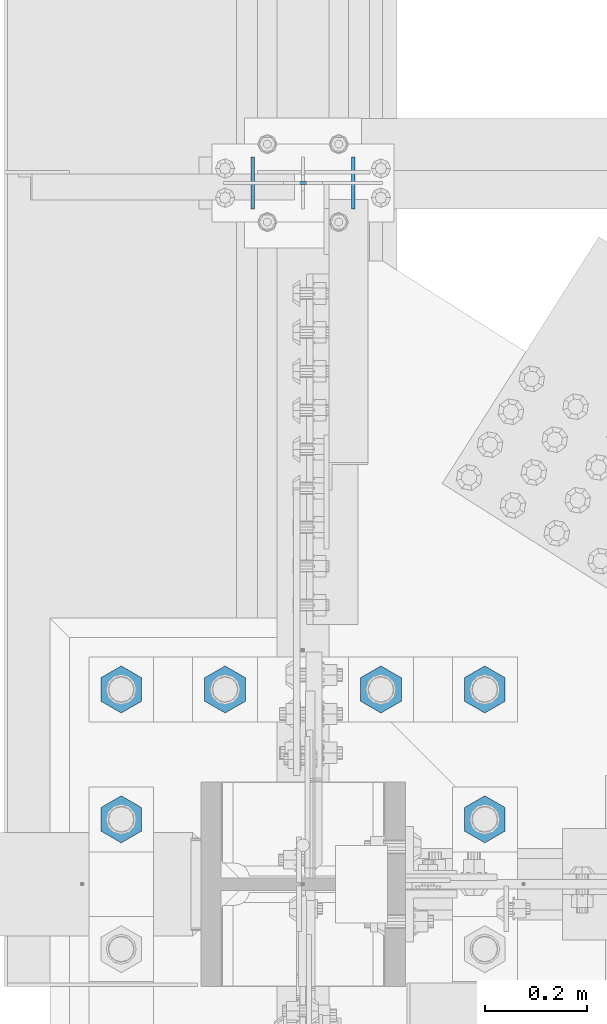
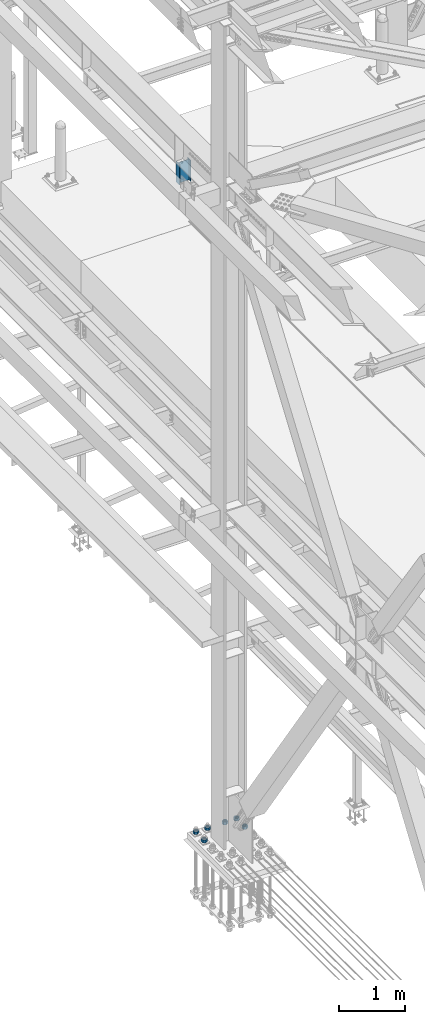
# One storey, part 1556 of 3843: 7 columns, 2 elements without a shape of their own.
"""IFC2X3 building model written with IfcOpenShell, lengths in millimetres."""

from ifc_helpers import new_model, si_unit, frame, origin_with_axes, place, context, subcontext, project, spatial, faceted_brep, material, type_object, element, aggregate, save


model = new_model("IFC2X3")

# Units and contexts
model_context = context("Model", 3, precision=1e-05, world=origin_with_axes())
body_context = subcontext(model_context, "Body", "Model", "MODEL_VIEW")
ifc_project = project(units=[si_unit("LENGTHUNIT", "METRE", prefix="MILLI"), si_unit("AREAUNIT", "SQUARE_METRE"), si_unit("VOLUMEUNIT", "CUBIC_METRE"), si_unit("MASSUNIT", "GRAM", prefix="KILO"), si_unit("TIMEUNIT", "SECOND"), si_unit("PLANEANGLEUNIT", "RADIAN"), si_unit("SOLIDANGLEUNIT", "STERADIAN"), si_unit("THERMODYNAMICTEMPERATUREUNIT", "DEGREE_CELSIUS"), si_unit("LUMINOUSINTENSITYUNIT", "LUMEN")], contexts=[model_context])

# Site, building, storey
site_placement = place(None, origin_with_axes())
site = spatial("IfcSite", under=ifc_project, at=site_placement, CompositionType="ELEMENT")
building_placement = place(site_placement, origin_with_axes())
building = spatial("IfcBuilding", under=site, at=building_placement, Name="Undefined", CompositionType="ELEMENT")
storey_placement = place(building_placement, origin_with_axes())
storey = spatial("IfcBuildingStorey", under=building, at=storey_placement, Name="Undefined", CompositionType="ELEMENT", Elevation=0.0)

# Assembly, column
assembly_1_placement = place(storey_placement, origin_with_axes())
assembly_1 = element("IfcElementAssembly", 1, at=assembly_1_placement, inside=storey, Name="POST", AssemblyPlace="NOTDEFINED", PredefinedType="RIGID_FRAME")
ifc_material_1 = material(Name="STEEL/A992")
column_type_1 = type_object("IfcColumnType", Name="W8X13", PredefinedType="NOTDEFINED")
column_1_placement = place(assembly_1_placement, frame((36576.0000030518, 77000.1, 41503.6), z_axis=(-1.0, 0.0, 0.0), x_axis=(0.0, 0.0, 1.0)))
column_1 = element("IfcColumn", 2, at=column_1_placement, type_object=column_type_1, material=ifc_material_1, Name="POST", ObjectType="W8X13", context=body_context, shape_type="Brep", body=[
    faceted_brep([(19.0499994920028, 50.7999999999993, -101.600000000035), (19.0499995237551, 50.7999999999993, -95.2500000000364), (403.224999428487, 50.7999999999993, -95.2499999989232), (403.22499939039, 50.7999999999993, -101.599999998929), (19.0499995237551, 3.17499999999927, -95.2500000000364), (403.224999428487, 3.17499999999927, -95.2499999989232), (19.0500004762507, 3.17499999999927, 95.2499999999636), (403.225000571489, 3.17499999999927, 95.2500000010768), (19.0500004762507, 50.7999999999993, 95.2499999999636), (403.225000571489, 50.7999999999993, 95.2500000010768), (19.050000508003, 50.7999999999993, 101.599999999969), (403.225000609593, 50.7999999999993, 101.600000001075), (19.050000508003, -50.7999999999993, 101.599999999969), (403.225000609593, -50.7999999999993, 101.600000001075), (19.0500004762507, -50.7999999999993, 95.2499999999636), (403.225000571489, -50.7999999999993, 95.2500000010768), (19.0500004762507, -3.17499999999927, 95.2499999999636), (403.225000571489, -3.17499999999927, 95.2500000010768), (19.0499995237551, -3.17499999999927, -95.2500000000364), (403.224999428487, -3.17499999999927, -95.2499999989232), (19.0499995237551, -50.7999999999993, -95.2500000000364), (403.224999428487, -50.7999999999993, -95.2499999989232), (19.0499994920028, -50.7999999999993, -101.600000000035), (403.22499939039, -50.7999999999993, -101.599999998929)], [[[0, 1, 2, 3]], [[1, 4, 5, 2]], [[4, 6, 7, 5]], [[6, 8, 9, 7]], [[8, 10, 11, 9]], [[10, 12, 13, 11]], [[12, 14, 15, 13]], [[14, 16, 17, 15]], [[16, 18, 19, 17]], [[18, 20, 21, 19]], [[20, 22, 23, 21]], [[22, 0, 3, 23]], [[5, 7, 9, 11, 13, 15, 17, 19, 21, 23, 3, 2]], [[22, 20, 18, 16, 14, 12, 10, 8, 6, 4, 1, 0]]]),
])
aggregate(assembly_1, [column_1])

# Assembly, columns
assembly_2_placement = place(storey_placement, origin_with_axes())
assembly_2 = element("IfcElementAssembly", 3, at=assembly_2_placement, inside=storey, Name="TEMPLATE", AssemblyPlace="NOTDEFINED", PredefinedType="RIGID_FRAME")
ifc_material_2 = material(Name="STEEL/A572-50")
column_type_2 = type_object("IfcColumnType", Name="2_HEAVY_HEX_NUT", PredefinedType="NOTDEFINED")
column_2_placement = place(assembly_2_placement, frame((36931.6, 75755.5, 30232.35), z_axis=(-1.0, 0.0, 0.0), x_axis=(0.0, 0.0, -1.0)))
column_2 = element("IfcColumn", 4, at=column_2_placement, type_object=column_type_2, material=ifc_material_2, Name="NUT", ObjectType="2_HEAVY_HEX_NUT", context=body_context, shape_type="Brep", body=[
    faceted_brep([(0.0, -46.0369987487793, 0.0), (0.0, -23.0184993743896, -39.869213104248), (50.7999999999993, -23.0184993743896, -39.869213104248), (50.7999999999993, -46.0369987487793, 0.0), (0.0, 23.0184993743896, -39.869213104248), (50.7999999999993, 23.0184993743896, -39.869213104248), (0.0, 46.0369987487793, 0.0), (50.7999999999993, 46.0369987487793, 0.0), (0.0, 23.0184993743896, 39.869213104248), (50.7999999999993, 23.0184993743896, 39.869213104248), (0.0, -23.0184993743896, 39.869213104248), (50.7999999999993, -23.0184993743896, 39.869213104248), (0.0, 0.0, 26.1940002441406), (0.0, 11.3650617044477, 23.5999013092805), (50.7999999999993, 11.3650617044477, 23.5999013092805), (50.7999999999993, 0.0, 26.1940002441406), (0.0, 20.4791109456419, 16.3316083006721), (50.7999999999993, 20.4791109456419, 16.3316083006721), (0.0, 25.5370200498292, 5.82867859874386), (50.7999999999993, 25.5370200498292, 5.82867859874386), (0.0, 25.5370200498292, -5.82867859874386), (50.7999999999993, 25.5370200498292, -5.82867859874386), (0.0, 20.4791109456419, -16.3316083006721), (50.7999999999993, 20.4791109456419, -16.3316083006721), (0.0, 11.3650617044477, -23.5999013092805), (50.7999999999993, 11.3650617044477, -23.5999013092805), (0.0, 0.0, -26.1940002441406), (50.7999999999993, 0.0, -26.1940002441406), (0.0, -11.3650617044477, -23.5999013092805), (50.7999999999993, -11.3650617044477, -23.5999013092805), (0.0, -20.4791109456419, -16.3316083006721), (50.7999999999993, -20.4791109456419, -16.3316083006721), (0.0, -25.5370200498292, -5.82867859874386), (50.7999999999993, -25.5370200498292, -5.82867859874386), (0.0, -25.5370200498292, 5.82867859874386), (50.7999999999993, -25.5370200498292, 5.82867859874386), (0.0, -20.4791109456419, 16.3316083006721), (50.7999999999993, -20.4791109456419, 16.3316083006721), (0.0, -11.3650617044477, 23.5999013092805), (50.7999999999993, -11.3650617044477, 23.5999013092805)], [[[0, 1, 2, 3]], [[1, 4, 5, 2]], [[4, 6, 7, 5]], [[6, 8, 9, 7]], [[8, 10, 11, 9]], [[10, 0, 3, 11]], [[12, 13, 14, 15]], [[13, 16, 17, 14]], [[16, 18, 19, 17]], [[18, 20, 21, 19]], [[20, 22, 23, 21]], [[22, 24, 25, 23]], [[24, 26, 27, 25]], [[26, 28, 29, 27]], [[28, 30, 31, 29]], [[30, 32, 33, 31]], [[32, 34, 35, 33]], [[34, 36, 37, 35]], [[36, 38, 39, 37]], [[38, 12, 15, 39]], [[5, 7, 9, 11, 3, 2], [17, 19, 21, 23, 25, 27, 29, 31, 33, 35, 37, 39, 15, 14]], [[10, 8, 6, 4, 1, 0], [38, 36, 34, 32, 30, 28, 26, 24, 22, 20, 18, 16, 13, 12]]]),
])
column_3_placement = place(assembly_2_placement, frame((36931.6, 76009.5, 30232.35), z_axis=(-1.0, 0.0, 0.0), x_axis=(0.0, 0.0, -1.0)))
column_3 = element("IfcColumn", 5, at=column_3_placement, type_object=column_type_2, material=ifc_material_2, Name="NUT", ObjectType="2_HEAVY_HEX_NUT", context=body_context, shape_type="Brep", body=[
    faceted_brep([(0.0, -46.0369987487793, 0.0), (0.0, -23.0184993743896, -39.869213104248), (50.7999999999993, -23.0184993743896, -39.869213104248), (50.7999999999993, -46.0369987487793, 0.0), (0.0, 23.0184993743896, -39.869213104248), (50.7999999999993, 23.0184993743896, -39.869213104248), (0.0, 46.0369987487793, 0.0), (50.7999999999993, 46.0369987487793, 0.0), (0.0, 23.0184993743896, 39.869213104248), (50.7999999999993, 23.0184993743896, 39.869213104248), (0.0, -23.0184993743896, 39.869213104248), (50.7999999999993, -23.0184993743896, 39.869213104248), (0.0, 0.0, 26.1940002441406), (0.0, 11.3650617044477, 23.5999013092805), (50.7999999999993, 11.3650617044477, 23.5999013092805), (50.7999999999993, 0.0, 26.1940002441406), (0.0, 20.4791109456419, 16.3316083006721), (50.7999999999993, 20.4791109456419, 16.3316083006721), (0.0, 25.5370200498292, 5.82867859874386), (50.7999999999993, 25.5370200498292, 5.82867859874386), (0.0, 25.5370200498292, -5.82867859874386), (50.7999999999993, 25.5370200498292, -5.82867859874386), (0.0, 20.4791109456419, -16.3316083006721), (50.7999999999993, 20.4791109456419, -16.3316083006721), (0.0, 11.3650617044477, -23.5999013092805), (50.7999999999993, 11.3650617044477, -23.5999013092805), (0.0, 0.0, -26.1940002441406), (50.7999999999993, 0.0, -26.1940002441406), (0.0, -11.3650617044477, -23.5999013092805), (50.7999999999993, -11.3650617044477, -23.5999013092805), (0.0, -20.4791109456419, -16.3316083006721), (50.7999999999993, -20.4791109456419, -16.3316083006721), (0.0, -25.5370200498292, -5.82867859874386), (50.7999999999993, -25.5370200498292, -5.82867859874386), (0.0, -25.5370200498292, 5.82867859874386), (50.7999999999993, -25.5370200498292, 5.82867859874386), (0.0, -20.4791109456419, 16.3316083006721), (50.7999999999993, -20.4791109456419, 16.3316083006721), (0.0, -11.3650617044477, 23.5999013092805), (50.7999999999993, -11.3650617044477, 23.5999013092805)], [[[0, 1, 2, 3]], [[1, 4, 5, 2]], [[4, 6, 7, 5]], [[6, 8, 9, 7]], [[8, 10, 11, 9]], [[10, 0, 3, 11]], [[12, 13, 14, 15]], [[13, 16, 17, 14]], [[16, 18, 19, 17]], [[18, 20, 21, 19]], [[20, 22, 23, 21]], [[22, 24, 25, 23]], [[24, 26, 27, 25]], [[26, 28, 29, 27]], [[28, 30, 31, 29]], [[30, 32, 33, 31]], [[32, 34, 35, 33]], [[34, 36, 37, 35]], [[36, 38, 39, 37]], [[38, 12, 15, 39]], [[5, 7, 9, 11, 3, 2], [17, 19, 21, 23, 25, 27, 29, 31, 33, 35, 37, 39, 15, 14]], [[10, 8, 6, 4, 1, 0], [38, 36, 34, 32, 30, 28, 26, 24, 22, 20, 18, 16, 13, 12]]]),
])
column_4_placement = place(assembly_2_placement, frame((36728.4, 76009.5, 30232.35), z_axis=(-1.0, 0.0, 0.0), x_axis=(0.0, 0.0, -1.0)))
column_4 = element("IfcColumn", 6, at=column_4_placement, type_object=column_type_2, material=ifc_material_2, Name="NUT", ObjectType="2_HEAVY_HEX_NUT", context=body_context, shape_type="Brep", body=[
    faceted_brep([(0.0, -46.0369987487793, 0.0), (0.0, -23.0184993743896, -39.869213104248), (50.7999999999993, -23.0184993743896, -39.869213104248), (50.7999999999993, -46.0369987487793, 0.0), (0.0, 23.0184993743896, -39.869213104248), (50.7999999999993, 23.0184993743896, -39.869213104248), (0.0, 46.0369987487793, 0.0), (50.7999999999993, 46.0369987487793, 0.0), (0.0, 23.0184993743896, 39.869213104248), (50.7999999999993, 23.0184993743896, 39.869213104248), (0.0, -23.0184993743896, 39.869213104248), (50.7999999999993, -23.0184993743896, 39.869213104248), (0.0, 0.0, 26.1940002441406), (0.0, 11.3650617044477, 23.5999013092805), (50.7999999999993, 11.3650617044477, 23.5999013092805), (50.7999999999993, 0.0, 26.1940002441406), (0.0, 20.4791109456419, 16.3316083006721), (50.7999999999993, 20.4791109456419, 16.3316083006721), (0.0, 25.5370200498292, 5.82867859874386), (50.7999999999993, 25.5370200498292, 5.82867859874386), (0.0, 25.5370200498292, -5.82867859874386), (50.7999999999993, 25.5370200498292, -5.82867859874386), (0.0, 20.4791109456419, -16.3316083006721), (50.7999999999993, 20.4791109456419, -16.3316083006721), (0.0, 11.3650617044477, -23.5999013092805), (50.7999999999993, 11.3650617044477, -23.5999013092805), (0.0, 0.0, -26.1940002441406), (50.7999999999993, 0.0, -26.1940002441406), (0.0, -11.3650617044477, -23.5999013092805), (50.7999999999993, -11.3650617044477, -23.5999013092805), (0.0, -20.4791109456419, -16.3316083006721), (50.7999999999993, -20.4791109456419, -16.3316083006721), (0.0, -25.5370200498292, -5.82867859874386), (50.7999999999993, -25.5370200498292, -5.82867859874386), (0.0, -25.5370200498292, 5.82867859874386), (50.7999999999993, -25.5370200498292, 5.82867859874386), (0.0, -20.4791109456419, 16.3316083006721), (50.7999999999993, -20.4791109456419, 16.3316083006721), (0.0, -11.3650617044477, 23.5999013092805), (50.7999999999993, -11.3650617044477, 23.5999013092805)], [[[0, 1, 2, 3]], [[1, 4, 5, 2]], [[4, 6, 7, 5]], [[6, 8, 9, 7]], [[8, 10, 11, 9]], [[10, 0, 3, 11]], [[12, 13, 14, 15]], [[13, 16, 17, 14]], [[16, 18, 19, 17]], [[18, 20, 21, 19]], [[20, 22, 23, 21]], [[22, 24, 25, 23]], [[24, 26, 27, 25]], [[26, 28, 29, 27]], [[28, 30, 31, 29]], [[30, 32, 33, 31]], [[32, 34, 35, 33]], [[34, 36, 37, 35]], [[36, 38, 39, 37]], [[38, 12, 15, 39]], [[5, 7, 9, 11, 3, 2], [17, 19, 21, 23, 25, 27, 29, 31, 33, 35, 37, 39, 15, 14]], [[10, 8, 6, 4, 1, 0], [38, 36, 34, 32, 30, 28, 26, 24, 22, 20, 18, 16, 13, 12]]]),
])
column_5_placement = place(assembly_2_placement, frame((36423.6, 76009.5, 30232.35), z_axis=(-1.0, 0.0, 0.0), x_axis=(0.0, 0.0, -1.0)))
column_5 = element("IfcColumn", 7, at=column_5_placement, type_object=column_type_2, material=ifc_material_2, Name="NUT", ObjectType="2_HEAVY_HEX_NUT", context=body_context, shape_type="Brep", body=[
    faceted_brep([(0.0, -46.0369987487793, 0.0), (0.0, -23.0184993743896, -39.869213104248), (50.7999999999993, -23.0184993743896, -39.869213104248), (50.7999999999993, -46.0369987487793, 0.0), (0.0, 23.0184993743896, -39.869213104248), (50.7999999999993, 23.0184993743896, -39.869213104248), (0.0, 46.0369987487793, 0.0), (50.7999999999993, 46.0369987487793, 0.0), (0.0, 23.0184993743896, 39.869213104248), (50.7999999999993, 23.0184993743896, 39.869213104248), (0.0, -23.0184993743896, 39.869213104248), (50.7999999999993, -23.0184993743896, 39.869213104248), (0.0, 0.0, 26.1940002441406), (0.0, 11.3650617044477, 23.5999013092805), (50.7999999999993, 11.3650617044477, 23.5999013092805), (50.7999999999993, 0.0, 26.1940002441406), (0.0, 20.4791109456419, 16.3316083006721), (50.7999999999993, 20.4791109456419, 16.3316083006721), (0.0, 25.5370200498292, 5.82867859874386), (50.7999999999993, 25.5370200498292, 5.82867859874386), (0.0, 25.5370200498292, -5.82867859874386), (50.7999999999993, 25.5370200498292, -5.82867859874386), (0.0, 20.4791109456419, -16.3316083006721), (50.7999999999993, 20.4791109456419, -16.3316083006721), (0.0, 11.3650617044477, -23.5999013092805), (50.7999999999993, 11.3650617044477, -23.5999013092805), (0.0, 0.0, -26.1940002441406), (50.7999999999993, 0.0, -26.1940002441406), (0.0, -11.3650617044477, -23.5999013092805), (50.7999999999993, -11.3650617044477, -23.5999013092805), (0.0, -20.4791109456419, -16.3316083006721), (50.7999999999993, -20.4791109456419, -16.3316083006721), (0.0, -25.5370200498292, -5.82867859874386), (50.7999999999993, -25.5370200498292, -5.82867859874386), (0.0, -25.5370200498292, 5.82867859874386), (50.7999999999993, -25.5370200498292, 5.82867859874386), (0.0, -20.4791109456419, 16.3316083006721), (50.7999999999993, -20.4791109456419, 16.3316083006721), (0.0, -11.3650617044477, 23.5999013092805), (50.7999999999993, -11.3650617044477, 23.5999013092805)], [[[0, 1, 2, 3]], [[1, 4, 5, 2]], [[4, 6, 7, 5]], [[6, 8, 9, 7]], [[8, 10, 11, 9]], [[10, 0, 3, 11]], [[12, 13, 14, 15]], [[13, 16, 17, 14]], [[16, 18, 19, 17]], [[18, 20, 21, 19]], [[20, 22, 23, 21]], [[22, 24, 25, 23]], [[24, 26, 27, 25]], [[26, 28, 29, 27]], [[28, 30, 31, 29]], [[30, 32, 33, 31]], [[32, 34, 35, 33]], [[34, 36, 37, 35]], [[36, 38, 39, 37]], [[38, 12, 15, 39]], [[5, 7, 9, 11, 3, 2], [17, 19, 21, 23, 25, 27, 29, 31, 33, 35, 37, 39, 15, 14]], [[10, 8, 6, 4, 1, 0], [38, 36, 34, 32, 30, 28, 26, 24, 22, 20, 18, 16, 13, 12]]]),
])
column_6_placement = place(assembly_2_placement, frame((36220.4, 75755.5, 30232.35), z_axis=(-1.0, 0.0, 0.0), x_axis=(0.0, 0.0, -1.0)))
column_6 = element("IfcColumn", 8, at=column_6_placement, type_object=column_type_2, material=ifc_material_2, Name="NUT", ObjectType="2_HEAVY_HEX_NUT", context=body_context, shape_type="Brep", body=[
    faceted_brep([(0.0, -46.0369987487793, 0.0), (0.0, -23.0184993743896, -39.869213104248), (50.7999999999993, -23.0184993743896, -39.869213104248), (50.7999999999993, -46.0369987487793, 0.0), (0.0, 23.0184993743896, -39.869213104248), (50.7999999999993, 23.0184993743896, -39.869213104248), (0.0, 46.0369987487793, 0.0), (50.7999999999993, 46.0369987487793, 0.0), (0.0, 23.0184993743896, 39.869213104248), (50.7999999999993, 23.0184993743896, 39.869213104248), (0.0, -23.0184993743896, 39.869213104248), (50.7999999999993, -23.0184993743896, 39.869213104248), (0.0, 0.0, 26.1940002441406), (0.0, 11.3650617044477, 23.5999013092805), (50.7999999999993, 11.3650617044477, 23.5999013092805), (50.7999999999993, 0.0, 26.1940002441406), (0.0, 20.4791109456419, 16.3316083006721), (50.7999999999993, 20.4791109456419, 16.3316083006721), (0.0, 25.5370200498292, 5.82867859874386), (50.7999999999993, 25.5370200498292, 5.82867859874386), (0.0, 25.5370200498292, -5.82867859874386), (50.7999999999993, 25.5370200498292, -5.82867859874386), (0.0, 20.4791109456419, -16.3316083006721), (50.7999999999993, 20.4791109456419, -16.3316083006721), (0.0, 11.3650617044477, -23.5999013092805), (50.7999999999993, 11.3650617044477, -23.5999013092805), (0.0, 0.0, -26.1940002441406), (50.7999999999993, 0.0, -26.1940002441406), (0.0, -11.3650617044477, -23.5999013092805), (50.7999999999993, -11.3650617044477, -23.5999013092805), (0.0, -20.4791109456419, -16.3316083006721), (50.7999999999993, -20.4791109456419, -16.3316083006721), (0.0, -25.5370200498292, -5.82867859874386), (50.7999999999993, -25.5370200498292, -5.82867859874386), (0.0, -25.5370200498292, 5.82867859874386), (50.7999999999993, -25.5370200498292, 5.82867859874386), (0.0, -20.4791109456419, 16.3316083006721), (50.7999999999993, -20.4791109456419, 16.3316083006721), (0.0, -11.3650617044477, 23.5999013092805), (50.7999999999993, -11.3650617044477, 23.5999013092805)], [[[0, 1, 2, 3]], [[1, 4, 5, 2]], [[4, 6, 7, 5]], [[6, 8, 9, 7]], [[8, 10, 11, 9]], [[10, 0, 3, 11]], [[12, 13, 14, 15]], [[13, 16, 17, 14]], [[16, 18, 19, 17]], [[18, 20, 21, 19]], [[20, 22, 23, 21]], [[22, 24, 25, 23]], [[24, 26, 27, 25]], [[26, 28, 29, 27]], [[28, 30, 31, 29]], [[30, 32, 33, 31]], [[32, 34, 35, 33]], [[34, 36, 37, 35]], [[36, 38, 39, 37]], [[38, 12, 15, 39]], [[5, 7, 9, 11, 3, 2], [17, 19, 21, 23, 25, 27, 29, 31, 33, 35, 37, 39, 15, 14]], [[10, 8, 6, 4, 1, 0], [38, 36, 34, 32, 30, 28, 26, 24, 22, 20, 18, 16, 13, 12]]]),
])
column_7_placement = place(assembly_2_placement, frame((36220.4, 76009.5, 30232.35), z_axis=(-1.0, 0.0, 0.0), x_axis=(0.0, 0.0, -1.0)))
column_7 = element("IfcColumn", 9, at=column_7_placement, type_object=column_type_2, material=ifc_material_2, Name="NUT", ObjectType="2_HEAVY_HEX_NUT", context=body_context, shape_type="Brep", body=[
    faceted_brep([(0.0, -46.0369987487793, 0.0), (0.0, -23.0184993743896, -39.869213104248), (50.7999999999993, -23.0184993743896, -39.869213104248), (50.7999999999993, -46.0369987487793, 0.0), (0.0, 23.0184993743896, -39.869213104248), (50.7999999999993, 23.0184993743896, -39.869213104248), (0.0, 46.0369987487793, 0.0), (50.7999999999993, 46.0369987487793, 0.0), (0.0, 23.0184993743896, 39.869213104248), (50.7999999999993, 23.0184993743896, 39.869213104248), (0.0, -23.0184993743896, 39.869213104248), (50.7999999999993, -23.0184993743896, 39.869213104248), (0.0, 0.0, 26.1940002441406), (0.0, 11.3650617044477, 23.5999013092805), (50.7999999999993, 11.3650617044477, 23.5999013092805), (50.7999999999993, 0.0, 26.1940002441406), (0.0, 20.4791109456419, 16.3316083006721), (50.7999999999993, 20.4791109456419, 16.3316083006721), (0.0, 25.5370200498292, 5.82867859874386), (50.7999999999993, 25.5370200498292, 5.82867859874386), (0.0, 25.5370200498292, -5.82867859874386), (50.7999999999993, 25.5370200498292, -5.82867859874386), (0.0, 20.4791109456419, -16.3316083006721), (50.7999999999993, 20.4791109456419, -16.3316083006721), (0.0, 11.3650617044477, -23.5999013092805), (50.7999999999993, 11.3650617044477, -23.5999013092805), (0.0, 0.0, -26.1940002441406), (50.7999999999993, 0.0, -26.1940002441406), (0.0, -11.3650617044477, -23.5999013092805), (50.7999999999993, -11.3650617044477, -23.5999013092805), (0.0, -20.4791109456419, -16.3316083006721), (50.7999999999993, -20.4791109456419, -16.3316083006721), (0.0, -25.5370200498292, -5.82867859874386), (50.7999999999993, -25.5370200498292, -5.82867859874386), (0.0, -25.5370200498292, 5.82867859874386), (50.7999999999993, -25.5370200498292, 5.82867859874386), (0.0, -20.4791109456419, 16.3316083006721), (50.7999999999993, -20.4791109456419, 16.3316083006721), (0.0, -11.3650617044477, 23.5999013092805), (50.7999999999993, -11.3650617044477, 23.5999013092805)], [[[0, 1, 2, 3]], [[1, 4, 5, 2]], [[4, 6, 7, 5]], [[6, 8, 9, 7]], [[8, 10, 11, 9]], [[10, 0, 3, 11]], [[12, 13, 14, 15]], [[13, 16, 17, 14]], [[16, 18, 19, 17]], [[18, 20, 21, 19]], [[20, 22, 23, 21]], [[22, 24, 25, 23]], [[24, 26, 27, 25]], [[26, 28, 29, 27]], [[28, 30, 31, 29]], [[30, 32, 33, 31]], [[32, 34, 35, 33]], [[34, 36, 37, 35]], [[36, 38, 39, 37]], [[38, 12, 15, 39]], [[5, 7, 9, 11, 3, 2], [17, 19, 21, 23, 25, 27, 29, 31, 33, 35, 37, 39, 15, 14]], [[10, 8, 6, 4, 1, 0], [38, 36, 34, 32, 30, 28, 26, 24, 22, 20, 18, 16, 13, 12]]]),
])
aggregate(assembly_2, [column_2, column_3, column_4, column_5, column_6, column_7])

save(model, "model.ifc")
